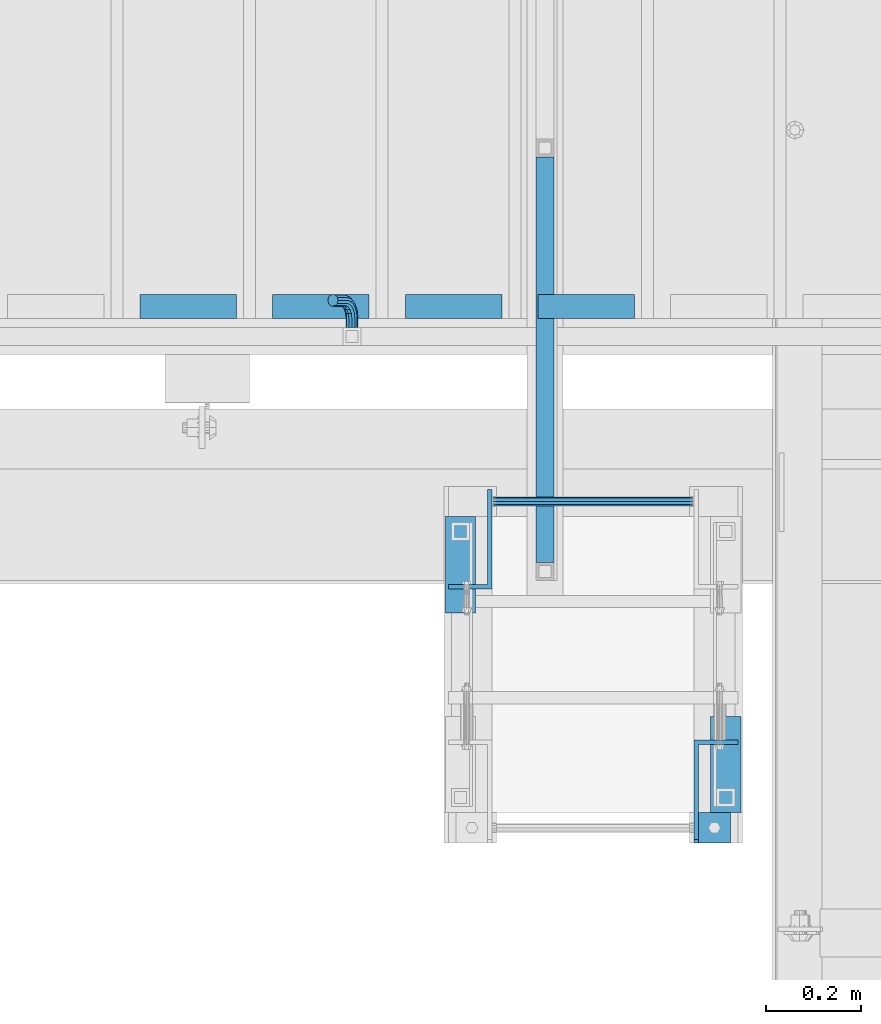
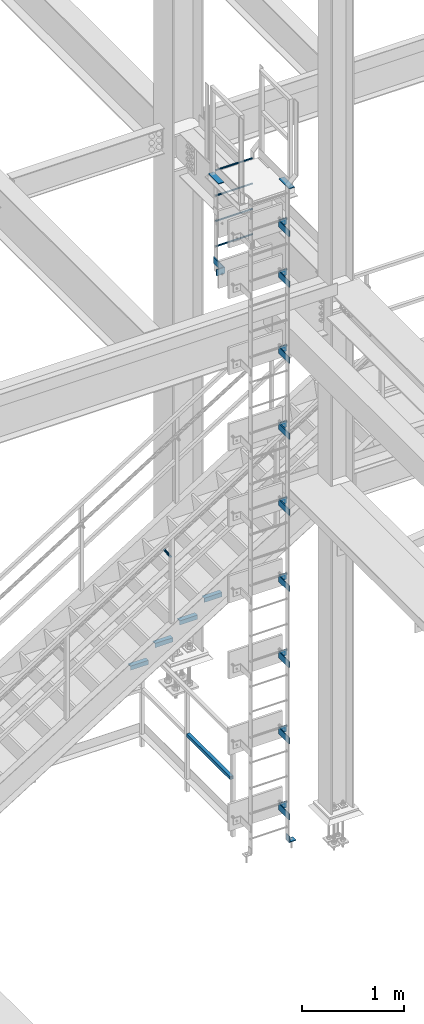
# One storey, part 2414 of 3843: 23 beams, 7 elements without a shape of their own.
"""IFC2X3 building model written with IfcOpenShell, lengths in millimetres."""

from ifc_helpers import new_model, si_unit, frame, origin_with_axes, place, context, subcontext, project, spatial, faceted_brep, material, type_object, element, aggregate, save


model = new_model("IFC2X3")

# Units and contexts
model_context = context("Model", 3, precision=1e-05, world=origin_with_axes())
body_context = subcontext(model_context, "Body", "Model", "MODEL_VIEW")
ifc_project = project(units=[si_unit("LENGTHUNIT", "METRE", prefix="MILLI"), si_unit("AREAUNIT", "SQUARE_METRE"), si_unit("VOLUMEUNIT", "CUBIC_METRE"), si_unit("MASSUNIT", "GRAM", prefix="KILO"), si_unit("TIMEUNIT", "SECOND"), si_unit("PLANEANGLEUNIT", "RADIAN"), si_unit("SOLIDANGLEUNIT", "STERADIAN"), si_unit("THERMODYNAMICTEMPERATUREUNIT", "DEGREE_CELSIUS"), si_unit("LUMINOUSINTENSITYUNIT", "LUMEN")], contexts=[model_context])

# Site, building, storey
site_placement = place(None, origin_with_axes())
site = spatial("IfcSite", under=ifc_project, at=site_placement, CompositionType="ELEMENT")
building_placement = place(site_placement, origin_with_axes())
building = spatial("IfcBuilding", under=site, at=building_placement, Name="Undefined", CompositionType="ELEMENT")
storey_placement = place(building_placement, origin_with_axes())
storey = spatial("IfcBuildingStorey", under=building, at=storey_placement, Name="Undefined", CompositionType="ELEMENT", Elevation=0.0)

# Assembly, beams
assembly_1_placement = place(storey_placement, origin_with_axes())
assembly_1 = element("IfcElementAssembly", 1, at=assembly_1_placement, inside=storey, Name="LADDER", AssemblyPlace="NOTDEFINED", PredefinedType="RIGID_FRAME")
ifc_material_1 = material(Name="STEEL/A36")
beam_type_1 = type_object("IfcBeamType", PredefinedType="NOTDEFINED")
beam_1_placement = place(assembly_1_placement, frame((35574.2874231775, 88297.1468750001, 37797.58125), z_axis=(0.0, 0.0, 1.0), x_axis=(0.0, 1.0, 0.0)))
beam_1 = element("IfcBeam", 2, at=beam_1_placement, type_object=beam_type_1, material=ifc_material_1, Name="BENT_PLATE", context=body_context, shape_type="Brep", body=[
    faceted_brep([(0.0, -4.76250000000073, -38.0999999999985), (0.0, -4.76250000000073, 38.0999999999985), (0.0, 4.76250000000073, 38.0999999999985), (0.0, 4.76250000000073, -38.0999999999985), (209.946875000009, 4.76249999998981, 38.0999999999985), (209.946875000009, 4.76249999998981, -38.0999999999985), (200.421875000015, -4.76250000000437, -38.0999999999985), (200.421875000015, -4.76250000000437, 38.0999999999985), (209.946875000009, -87.3125, 38.0999999999985), (209.946875000009, -87.3125, -38.0999999999985), (200.421875000015, -87.3125, 38.0999999999985), (200.421875000015, -87.3125, -38.0999999999985)], [[[0, 1, 2, 3]], [[3, 2, 4, 5]], [[1, 0, 6, 7]], [[5, 4, 8, 9]], [[4, 2, 1, 7, 10, 8]], [[7, 6, 11, 10]], [[6, 0, 3, 5, 9, 11]], [[10, 11, 9, 8]]]),
])
beam_2_placement = place(assembly_1_placement, frame((35574.2874231775, 88297.1468750001, 37187.98125), z_axis=(0.0, 0.0, 1.0), x_axis=(0.0, 1.0, 0.0)))
beam_2 = element("IfcBeam", 3, at=beam_2_placement, type_object=beam_type_1, material=ifc_material_1, Name="BENT_PLATE", context=body_context, shape_type="Brep", body=[
    faceted_brep([(0.0, -4.76250000000073, -38.0999999999985), (0.0, -4.76250000000073, 38.0999999999985), (0.0, 4.76250000000073, 38.0999999999985), (0.0, 4.76250000000073, -38.0999999999985), (209.946875000009, 4.76249999998981, 38.0999999999985), (209.946875000009, 4.76249999998981, -38.0999999999985), (200.421875000015, -4.76250000000437, -38.0999999999985), (200.421875000015, -4.76250000000437, 38.0999999999985), (209.946875000009, -87.3125, 38.0999999999985), (209.946875000009, -87.3125, -38.0999999999985), (200.421875000015, -87.3125, 38.0999999999985), (200.421875000015, -87.3125, -38.0999999999985)], [[[0, 1, 2, 3]], [[3, 2, 4, 5]], [[1, 0, 6, 7]], [[5, 4, 8, 9]], [[4, 2, 1, 7, 10, 8]], [[7, 6, 11, 10]], [[6, 0, 3, 5, 9, 11]], [[10, 11, 9, 8]]]),
])
beam_3_placement = place(assembly_1_placement, frame((35574.2874231775, 88297.1468750001, 36273.58125), z_axis=(0.0, 0.0, 1.0), x_axis=(0.0, 1.0, 0.0)))
beam_3 = element("IfcBeam", 4, at=beam_3_placement, type_object=beam_type_1, material=ifc_material_1, Name="BENT_PLATE", context=body_context, shape_type="Brep", body=[
    faceted_brep([(0.0, -4.76250000000073, -38.0999999999985), (0.0, -4.76250000000073, 38.0999999999985), (0.0, 4.76250000000073, 38.0999999999985), (0.0, 4.76250000000073, -38.0999999999985), (209.946875000009, 4.76249999998981, 38.0999999999985), (209.946875000009, 4.76249999998981, -38.0999999999985), (200.421875000015, -4.76250000000437, -38.0999999999985), (200.421875000015, -4.76250000000437, 38.0999999999985), (209.946875000009, -87.3125, 38.0999999999985), (209.946875000009, -87.3125, -38.0999999999985), (200.421875000015, -87.3125, 38.0999999999985), (200.421875000015, -87.3125, -38.0999999999985)], [[[0, 1, 2, 3]], [[3, 2, 4, 5]], [[1, 0, 6, 7]], [[5, 4, 8, 9]], [[4, 2, 1, 7, 10, 8]], [[7, 6, 11, 10]], [[6, 0, 3, 5, 9, 11]], [[10, 11, 9, 8]]]),
])
beam_4_placement = place(assembly_1_placement, frame((35574.2874231775, 88297.1468750001, 35359.18125), z_axis=(0.0, 0.0, 1.0), x_axis=(0.0, 1.0, 0.0)))
beam_4 = element("IfcBeam", 5, at=beam_4_placement, type_object=beam_type_1, material=ifc_material_1, Name="BENT_PLATE", context=body_context, shape_type="Brep", body=[
    faceted_brep([(0.0, -4.76250000000073, -38.0999999999985), (0.0, -4.76250000000073, 38.0999999999985), (0.0, 4.76250000000073, 38.0999999999985), (0.0, 4.76250000000073, -38.0999999999985), (209.946875000009, 4.76249999998981, 38.0999999999985), (209.946875000009, 4.76249999998981, -38.0999999999985), (200.421875000015, -4.76250000000437, -38.0999999999985), (200.421875000015, -4.76250000000437, 38.0999999999985), (209.946875000009, -87.3125, 38.0999999999985), (209.946875000009, -87.3125, -38.0999999999985), (200.421875000015, -87.3125, 38.0999999999985), (200.421875000015, -87.3125, -38.0999999999985)], [[[0, 1, 2, 3]], [[3, 2, 4, 5]], [[1, 0, 6, 7]], [[5, 4, 8, 9]], [[4, 2, 1, 7, 10, 8]], [[7, 6, 11, 10]], [[6, 0, 3, 5, 9, 11]], [[10, 11, 9, 8]]]),
])
beam_5_placement = place(assembly_1_placement, frame((35574.2874231775, 88297.1468750001, 34444.78125), z_axis=(0.0, 0.0, 1.0), x_axis=(0.0, 1.0, 0.0)))
beam_5 = element("IfcBeam", 6, at=beam_5_placement, type_object=beam_type_1, material=ifc_material_1, Name="BENT_PLATE", context=body_context, shape_type="Brep", body=[
    faceted_brep([(0.0, -4.76250000000073, -38.0999999999985), (0.0, -4.76250000000073, 38.0999999999985), (0.0, 4.76250000000073, 38.0999999999985), (0.0, 4.76250000000073, -38.0999999999985), (209.946875000009, 4.76249999998981, 38.0999999999985), (209.946875000009, 4.76249999998981, -38.0999999999985), (200.421875000015, -4.76250000000437, -38.0999999999985), (200.421875000015, -4.76250000000437, 38.0999999999985), (209.946875000009, -87.3125, 38.0999999999985), (209.946875000009, -87.3125, -38.0999999999985), (200.421875000015, -87.3125, 38.0999999999985), (200.421875000015, -87.3125, -38.0999999999985)], [[[0, 1, 2, 3]], [[3, 2, 4, 5]], [[1, 0, 6, 7]], [[5, 4, 8, 9]], [[4, 2, 1, 7, 10, 8]], [[7, 6, 11, 10]], [[6, 0, 3, 5, 9, 11]], [[10, 11, 9, 8]]]),
])
beam_6_placement = place(assembly_1_placement, frame((35574.2874231775, 88297.1468750001, 33530.38125), z_axis=(0.0, 0.0, 1.0), x_axis=(0.0, 1.0, 0.0)))
beam_6 = element("IfcBeam", 7, at=beam_6_placement, type_object=beam_type_1, material=ifc_material_1, Name="BENT_PLATE", context=body_context, shape_type="Brep", body=[
    faceted_brep([(0.0, -4.76250000000073, -38.0999999999985), (0.0, -4.76250000000073, 38.0999999999985), (0.0, 4.76250000000073, 38.0999999999985), (0.0, 4.76250000000073, -38.0999999999985), (209.946875000009, 4.76249999998981, 38.0999999999985), (209.946875000009, 4.76249999998981, -38.0999999999985), (200.421875000015, -4.76250000000437, -38.0999999999985), (200.421875000015, -4.76250000000437, 38.0999999999985), (209.946875000009, -87.3125, 38.0999999999985), (209.946875000009, -87.3125, -38.0999999999985), (200.421875000015, -87.3125, 38.0999999999985), (200.421875000015, -87.3125, -38.0999999999985)], [[[0, 1, 2, 3]], [[3, 2, 4, 5]], [[1, 0, 6, 7]], [[5, 4, 8, 9]], [[4, 2, 1, 7, 10, 8]], [[7, 6, 11, 10]], [[6, 0, 3, 5, 9, 11]], [[10, 11, 9, 8]]]),
])
beam_7_placement = place(assembly_1_placement, frame((35574.2874231775, 88297.1468750001, 32615.98125), z_axis=(0.0, 0.0, 1.0), x_axis=(0.0, 1.0, 0.0)))
beam_7 = element("IfcBeam", 8, at=beam_7_placement, type_object=beam_type_1, material=ifc_material_1, Name="BENT_PLATE", context=body_context, shape_type="Brep", body=[
    faceted_brep([(0.0, -4.76250000000073, -38.0999999999985), (0.0, -4.76250000000073, 38.0999999999985), (0.0, 4.76250000000073, 38.0999999999985), (0.0, 4.76250000000073, -38.0999999999985), (209.946875000009, 4.76249999998981, 38.0999999999985), (209.946875000009, 4.76249999998981, -38.0999999999985), (200.421875000015, -4.76250000000437, -38.0999999999985), (200.421875000015, -4.76250000000437, 38.0999999999985), (209.946875000009, -87.3125, 38.0999999999985), (209.946875000009, -87.3125, -38.0999999999985), (200.421875000015, -87.3125, 38.0999999999985), (200.421875000015, -87.3125, -38.0999999999985)], [[[0, 1, 2, 3]], [[3, 2, 4, 5]], [[1, 0, 6, 7]], [[5, 4, 8, 9]], [[4, 2, 1, 7, 10, 8]], [[7, 6, 11, 10]], [[6, 0, 3, 5, 9, 11]], [[10, 11, 9, 8]]]),
])

# Assembly, beam
assembly_2_placement = place(storey_placement, origin_with_axes())
assembly_2 = element("IfcElementAssembly", 9, at=assembly_2_placement, inside=storey, Name="LADDER", AssemblyPlace="NOTDEFINED", PredefinedType="RIGID_FRAME")
beam_8_placement = place(assembly_2_placement, frame((35139.3126300871, 89034.2771634689, 37188.0390686035), z_axis=(0.0, 0.0, 1.0), x_axis=(0.0, -1.0, 0.0)))
beam_8 = element("IfcBeam", 10, at=beam_8_placement, type_object=beam_type_1, material=ifc_material_1, Name="BENT_PLATE", context=body_context, shape_type="Brep", body=[
    faceted_brep([(0.0, -4.76250000000073, -38.0999999999985), (0.0, -4.76250000000073, 38.0999999999985), (0.0, 4.76250000000073, 38.0999999999985), (0.0, 4.76250000000073, -38.0999999999985), (209.745611795166, 4.76250006725604, 38.0999999999985), (209.745611795166, 4.76250006725604, -38.0999999999985), (200.220604794216, -4.76249993579404, -38.0999999999985), (200.220604794216, -4.76249993579404, 38.0999999999985), (209.745544119389, -87.3125069349044, 38.0999999999985), (209.745544119389, -87.3125069349044, -38.0999999999985), (200.22054411938, -87.3124999339561, 38.0999999999985), (200.22054411938, -87.3124999339561, -38.0999999999985)], [[[0, 1, 2, 3]], [[3, 2, 4, 5]], [[1, 0, 6, 7]], [[5, 4, 8, 9]], [[4, 2, 1, 7, 10, 8]], [[7, 6, 11, 10]], [[6, 0, 3, 5, 9, 11]], [[10, 11, 9, 8]]]),
])

# Beam
beam_9_placement = place(assembly_1_placement, frame((35574.2874231775, 88297.1710895375, 31701.6384658952), z_axis=(0.0, 0.000284300999875996, 0.99999995958647), x_axis=(0.0, 0.99999995958647, -0.000284300999878262)))
beam_9 = element("IfcBeam", 11, at=beam_9_placement, type_object=beam_type_1, material=ifc_material_1, Name="BENT_PLATE", context=body_context, shape_type="Brep", body=[
    faceted_brep([(0.0, -4.76250000000073, -38.0999999999985), (0.0, -4.76250000000073, 38.0999999999985), (0.0, 4.76250000000073, 38.0999999999985), (0.0, 4.76250000000073, -38.0999999999985), (209.9131736126, 4.76249999998981, 38.099999999813), (209.913173612542, 4.76249999998981, -38.1000000001295), (200.388173612504, -4.76250000000437, -38.1000000001222), (200.388173612562, -4.76250000000437, 38.0999999998203), (209.9131736126, -87.3125000188884, 38.099999999813), (209.913173612542, -87.3125000188884, -38.1000000001295), (200.388173612562, -87.3125000188884, 38.0999999998203), (200.388173612504, -87.3125000188884, -38.1000000001222)], [[[0, 1, 2, 3]], [[3, 2, 4, 5]], [[1, 0, 6, 7]], [[5, 4, 8, 9]], [[4, 2, 1, 7, 10, 8]], [[7, 6, 11, 10]], [[6, 0, 3, 5, 9, 11]], [[10, 11, 9, 8]]]),
])

beam_10_placement = place(assembly_1_placement, frame((35574.2876798629, 88296.9241128497, 30787.2367905276), z_axis=(0.0, 2.02899999567308e-06, 0.999999999997942), x_axis=(0.0, 0.999999999997942, -2.02899998962774e-06)))
beam_10 = element("IfcBeam", 12, at=beam_10_placement, type_object=beam_type_1, material=ifc_material_1, Name="BENT_PLATE", context=body_context, shape_type="Brep", body=[
    faceted_brep([(0.0, -4.76250000000073, -38.0999999999985), (0.0, -4.76250000000073, 38.0999999999985), (0.0, 4.76250000000073, 38.0999999999985), (0.0, 4.76250000000073, -38.0999999999985), (210.094866646919, 4.76249999998981, 38.1000000001186), (210.094866646992, 4.76249999998981, -38.0999999999876), (200.569866646983, -4.76250000000437, -38.0999999999876), (200.569866646925, -4.76250000000437, 38.100000000115), (210.094866647079, -87.3124999846914, 38.1000000004824), (210.094866646832, -87.3124999850115, -38.0999999996238), (200.569866647085, -87.3124999846914, 38.1000000004788), (200.569866646823, -87.3124999850115, -38.0999999996275)], [[[0, 1, 2, 3]], [[3, 2, 4, 5]], [[1, 0, 6, 7]], [[5, 4, 8, 9]], [[4, 2, 1, 7, 10, 8]], [[7, 6, 11, 10]], [[6, 0, 3, 5, 9, 11]], [[10, 11, 9, 8]]]),
])

ifc_material_2 = material(Name="STEEL/A572-50")
beam_type_2 = type_object("IfcBeamType", Name="L3X3X3/8", PredefinedType="NOTDEFINED")
beam_11_placement = place(assembly_1_placement, frame((35607.6251798629, 88353.6303589472, 30518.1), z_axis=(1.0, 0.0, 0.0), x_axis=(0.0, -1.0, 0.0)))
beam_11 = element("IfcBeam", 13, at=beam_11_placement, type_object=beam_type_2, material=ifc_material_2, Name="ANGLE", ObjectType="L3X3X3/8", context=body_context, shape_type="Brep", body=[
    faceted_brep([(0.0, 38.0999999999985, -38.0999999999985), (0.0, 38.0999999999985, 38.0999999999985), (63.5, 38.0999999999985, 38.0999999999985), (63.5, 38.0999999999985, -38.0999999999985), (0.0, 28.5750000000007, 38.0999999999985), (63.5, 28.5750000000007, 38.0999999999985), (0.0, 28.5750000000007, -28.5750000000007), (63.5, 28.5750000000007, -28.5750000000007), (0.0, -38.0999999999985, -28.5750000000007), (63.5, -38.0999999999985, -28.5750000000007), (0.0, -38.0999999999985, -38.0999999999985), (63.5, -38.0999999999985, -38.0999999999985)], [[[0, 1, 2, 3]], [[1, 4, 5, 2]], [[4, 6, 7, 5]], [[6, 8, 9, 7]], [[8, 10, 11, 9]], [[10, 0, 3, 11]], [[5, 7, 9, 11, 3, 2]], [[10, 8, 6, 4, 1, 0]]]),
])

aggregate(assembly_1, [beam_1, beam_2, beam_3, beam_4, beam_5, beam_6, beam_7, beam_11, beam_9, beam_10])

# Assembly, beam
assembly_3_placement = place(storey_placement, origin_with_axes())
assembly_3 = element("IfcElementAssembly", 14, at=assembly_3_placement, inside=storey, Name="RAIL", AssemblyPlace="NOTDEFINED", PredefinedType="RIGID_FRAME")
ifc_material_3 = material()
beam_type_3 = type_object("IfcBeamType", Name="HSS1-1/2X1-1/2X1/4", PredefinedType="NOTDEFINED")
beam_12_placement = place(assembly_3_placement, frame((35255.2000000271, 88861.9, 31013.4), z_axis=(0.0, 0.0, 1.0), x_axis=(0.0, 1.0, 0.0)))
beam_12 = element("IfcBeam", 15, at=beam_12_placement, type_object=beam_type_3, material=ifc_material_3, Name="RAIL", ObjectType="HSS1-1/2X1-1/2X1/4", context=body_context, shape_type="Brep", body=[
    faceted_brep([(873.125000004831, -19.0499999999884, 19.0499992350015), (873.125000004831, -19.0499992350015, -19.0499992350015), (873.125000004831, 19.0499992350015, -19.0499992350015), (873.125000004831, 19.0499992350015, 19.0499992350015), (873.125000004831, -12.6999993299978, 12.6999993300014), (873.125000004831, 12.6999993299978, 12.6999993300014), (873.125000004831, 12.6999993299978, -12.6999993300014), (873.125000004831, -12.6999993299978, -12.6999993300014), (19.0499992350015, 19.0499992350015, -19.0499992350015), (19.0499992350015, 19.0499992350015, 19.0499992350015), (19.0499992350015, -19.0499992350015, 19.0499992350015), (19.0499992350015, -19.0499992350015, -19.0499992350015), (19.0499992350015, 12.6999993299978, 12.6999993299978), (19.0499992350015, -12.6999993299978, 12.6999993299978), (19.0499992350015, -12.6999993299978, -12.6999993299978), (19.0499992350015, 12.6999993299978, -12.6999993299978)], [[[0, 1, 2, 3], [4, 5, 6, 7]], [[8, 9, 3, 2]], [[9, 10, 0, 3]], [[10, 11, 1, 0]], [[11, 8, 2, 1]], [[11, 10, 9, 8], [12, 13, 14, 15]], [[14, 13, 4, 7]], [[15, 14, 7, 6]], [[12, 15, 6, 5]], [[13, 12, 5, 4]]]),
])
aggregate(assembly_3, [beam_12])

# Assembly, beams
assembly_4_placement = place(storey_placement, origin_with_axes())
assembly_4 = element("IfcElementAssembly", 16, at=assembly_4_placement, inside=storey, Name="STAIR", AssemblyPlace="NOTDEFINED", PredefinedType="RIGID_FRAME")
beam_type_4 = type_object("IfcBeamType", Name="L2X2X3/16", PredefinedType="NOTDEFINED")
beam_13_placement = place(assembly_4_placement, frame((35443.6169176732, 89420.7000000434, 32839.0250000043), z_axis=(0.0, 1.0, 0.0), x_axis=(-1.0, 0.0, 0.0)))
beam_13 = element("IfcBeam", 17, at=beam_13_placement, type_object=beam_type_4, material=ifc_material_1, Name="ANGLE", ObjectType="L2X2X3/16", context=body_context, shape_type="Brep", body=[
    faceted_brep([(0.0, 25.4000000000015, -25.4000000000015), (0.0, 25.4000000000015, 25.4000000000015), (203.199999999997, 25.4000000000015, 25.4000000000015), (203.199999999997, 25.4000000000015, -25.4000000000015), (0.0, 20.6375000000007, 25.4000000000015), (203.199999999997, 20.6375000000007, 25.4000000000015), (0.0, 20.6375000000007, -20.6375000000007), (203.199999999997, 20.6375000000007, -20.6375000000007), (0.0, -25.4000000000015, -20.6375000000007), (203.199999999997, -25.4000000000015, -20.6375000000007), (0.0, -25.4000000000015, -25.4000000000015), (203.199999999997, -25.4000000000015, -25.4000000000015)], [[[0, 1, 2, 3]], [[1, 4, 5, 2]], [[4, 6, 7, 5]], [[6, 8, 9, 7]], [[8, 10, 11, 9]], [[10, 0, 3, 11]], [[5, 7, 9, 11, 3, 2]], [[10, 8, 6, 4, 1, 0]]]),
])
beam_14_placement = place(assembly_4_placement, frame((35164.2169176732, 89420.7000000434, 32664.8535714329), z_axis=(0.0, 1.0, 0.0), x_axis=(-1.0, 0.0, 0.0)))
beam_14 = element("IfcBeam", 18, at=beam_14_placement, type_object=beam_type_4, material=ifc_material_1, Name="ANGLE", ObjectType="L2X2X3/16", context=body_context, shape_type="Brep", body=[
    faceted_brep([(0.0, 25.4000000000015, -25.4000000000015), (0.0, 25.4000000000015, 25.4000000000015), (203.199999999997, 25.4000000000015, 25.4000000000015), (203.199999999997, 25.4000000000015, -25.4000000000015), (0.0, 20.6375000000007, 25.4000000000015), (203.199999999997, 20.6375000000007, 25.4000000000015), (0.0, 20.6375000000007, -20.6375000000007), (203.199999999997, 20.6375000000007, -20.6375000000007), (0.0, -25.4000000000015, -20.6375000000007), (203.199999999997, -25.4000000000015, -20.6375000000007), (0.0, -25.4000000000015, -25.4000000000015), (203.199999999997, -25.4000000000015, -25.4000000000015)], [[[0, 1, 2, 3]], [[1, 4, 5, 2]], [[4, 6, 7, 5]], [[6, 8, 9, 7]], [[8, 10, 11, 9]], [[10, 0, 3, 11]], [[5, 7, 9, 11, 3, 2]], [[10, 8, 6, 4, 1, 0]]]),
])
beam_15_placement = place(assembly_4_placement, frame((34884.8169176732, 89420.7000000434, 32490.6821428615), z_axis=(0.0, 1.0, 0.0), x_axis=(-1.0, 0.0, 0.0)))
beam_15 = element("IfcBeam", 19, at=beam_15_placement, type_object=beam_type_4, material=ifc_material_1, Name="ANGLE", ObjectType="L2X2X3/16", context=body_context, shape_type="Brep", body=[
    faceted_brep([(0.0, 25.4000000000015, -25.4000000000015), (0.0, 25.4000000000015, 25.4000000000015), (203.199999999997, 25.4000000000015, 25.4000000000015), (203.199999999997, 25.4000000000015, -25.4000000000015), (0.0, 20.6375000000007, 25.4000000000015), (203.199999999997, 20.6375000000007, 25.4000000000015), (0.0, 20.6375000000007, -20.6375000000007), (203.199999999997, 20.6375000000007, -20.6375000000007), (0.0, -25.4000000000015, -20.6375000000007), (203.199999999997, -25.4000000000015, -20.6375000000007), (0.0, -25.4000000000015, -25.4000000000015), (203.199999999997, -25.4000000000015, -25.4000000000015)], [[[0, 1, 2, 3]], [[1, 4, 5, 2]], [[4, 6, 7, 5]], [[6, 8, 9, 7]], [[8, 10, 11, 9]], [[10, 0, 3, 11]], [[5, 7, 9, 11, 3, 2]], [[10, 8, 6, 4, 1, 0]]]),
])
beam_16_placement = place(assembly_4_placement, frame((34605.4169176732, 89420.7000000434, 32316.51071429), z_axis=(0.0, 1.0, 0.0), x_axis=(-1.0, 0.0, 0.0)))
beam_16 = element("IfcBeam", 20, at=beam_16_placement, type_object=beam_type_4, material=ifc_material_1, Name="ANGLE", ObjectType="L2X2X3/16", context=body_context, shape_type="Brep", body=[
    faceted_brep([(0.0, 25.4000000000015, -25.4000000000015), (0.0, 25.4000000000015, 25.4000000000015), (203.199999999997, 25.4000000000015, 25.4000000000015), (203.199999999997, 25.4000000000015, -25.4000000000015), (0.0, 20.6375000000007, 25.4000000000015), (203.199999999997, 20.6375000000007, 25.4000000000015), (0.0, 20.6375000000007, -20.6375000000007), (203.199999999997, 20.6375000000007, -20.6375000000007), (0.0, -25.4000000000015, -20.6375000000007), (203.199999999997, -25.4000000000015, -20.6375000000007), (0.0, -25.4000000000015, -25.4000000000015), (203.199999999997, -25.4000000000015, -25.4000000000015)], [[[0, 1, 2, 3]], [[1, 4, 5, 2]], [[4, 6, 7, 5]], [[6, 8, 9, 7]], [[8, 10, 11, 9]], [[10, 0, 3, 11]], [[5, 7, 9, 11, 3, 2]], [[10, 8, 6, 4, 1, 0]]]),
])
aggregate(assembly_4, [beam_13, beam_14, beam_15, beam_16])

# Beam
beam_type_5 = type_object("IfcBeamType", PredefinedType="NOTDEFINED")
beam_17_placement = place(assembly_2_placement, frame((35147.2501477523, 89009.6477544666, 37362.9359471553), z_axis=(0.0, 1.0, 0.0), x_axis=(1.0, 0.0, 0.0)))
beam_17 = element("IfcBeam", 21, at=beam_17_placement, type_object=beam_type_5, material=ifc_material_2, Name="RUNG", context=body_context, shape_type="Brep", body=[
    faceted_brep([(0.0, -9.52500000000146, 0.0), (0.0, -6.73519209080405, -6.73519209079677), (419.100000000006, -6.73519209080405, -6.73519209079677), (419.100000000006, -9.52500000000146, 0.0), (2.95075507493764e-12, 2.91322521661641e-12, -9.52499961853027), (419.100000000006, 0.0, -9.52499999999418), (0.0, 6.73519209080405, -6.73519209079677), (419.100000000006, 6.73519209080405, -6.73519209079677), (0.0, 9.52500000000146, 0.0), (419.100000000006, 9.52500000000146, 0.0), (0.0, 6.73519209080405, 6.73519209079677), (419.100000000006, 6.73519209080405, 6.73519209079677), (-9.87109982941227e-13, 2.91322521661641e-12, 9.52499961853027), (419.100000000006, 0.0, 9.52499999999418), (0.0, -6.73519209080405, 6.73519209079677), (419.100000000006, -6.73519209080405, 6.73519209079677)], [[[0, 1, 2, 3]], [[1, 4, 5, 2]], [[4, 6, 7, 5]], [[6, 8, 9, 7]], [[8, 10, 11, 9]], [[10, 12, 13, 11]], [[12, 14, 15, 13]], [[14, 0, 3, 15]], [[5, 7, 9, 11, 13, 15, 3, 2]], [[14, 12, 10, 8, 6, 4, 1, 0]]]),
])

beam_18_placement = place(assembly_2_placement, frame((35147.2501477523, 89009.6477544666, 37667.7359471553), z_axis=(0.0, 1.0, 0.0), x_axis=(1.0, 0.0, 0.0)))
beam_18 = element("IfcBeam", 22, at=beam_18_placement, type_object=beam_type_5, material=ifc_material_2, Name="RUNG", context=body_context, shape_type="Brep", body=[
    faceted_brep([(0.0, -9.52500000000146, 0.0), (0.0, -6.73519209080405, -6.73519209079677), (419.100000000006, -6.73519209080405, -6.73519209079677), (419.100000000006, -9.52500000000146, 0.0), (2.95075507493764e-12, 2.91322521661641e-12, -9.52499961853027), (419.100000000006, 0.0, -9.52499999999418), (0.0, 6.73519209080405, -6.73519209079677), (419.100000000006, 6.73519209080405, -6.73519209079677), (0.0, 9.52500000000146, 0.0), (419.100000000006, 9.52500000000146, 0.0), (0.0, 6.73519209080405, 6.73519209079677), (419.100000000006, 6.73519209080405, 6.73519209079677), (-9.87109982941227e-13, 2.91322521661641e-12, 9.52499961853027), (419.100000000006, 0.0, 9.52499999999418), (0.0, -6.73519209080405, 6.73519209079677), (419.100000000006, -6.73519209080405, 6.73519209079677)], [[[0, 1, 2, 3]], [[1, 4, 5, 2]], [[4, 6, 7, 5]], [[6, 8, 9, 7]], [[8, 10, 11, 9]], [[10, 12, 13, 11]], [[12, 14, 15, 13]], [[14, 0, 3, 15]], [[5, 7, 9, 11, 13, 15, 3, 2]], [[14, 12, 10, 8, 6, 4, 1, 0]]]),
])

beam_19_placement = place(assembly_2_placement, frame((35147.2501477523, 89009.6477544666, 37972.5359471553), z_axis=(0.0, 1.0, 0.0), x_axis=(1.0, 0.0, 0.0)))
beam_19 = element("IfcBeam", 23, at=beam_19_placement, type_object=beam_type_5, material=ifc_material_2, Name="RUNG", context=body_context, shape_type="Brep", body=[
    faceted_brep([(0.0, -9.52500000000146, 0.0), (0.0, -6.73519209080405, -6.73519209079677), (419.100000000006, -6.73519209080405, -6.73519209079677), (419.100000000006, -9.52500000000146, 0.0), (2.95075507493764e-12, 2.91322521661641e-12, -9.52499961853027), (419.100000000006, 0.0, -9.52499999999418), (0.0, 6.73519209080405, -6.73519209079677), (419.100000000006, 6.73519209080405, -6.73519209079677), (0.0, 9.52500000000146, 0.0), (419.100000000006, 9.52500000000146, 0.0), (0.0, 6.73519209080405, 6.73519209079677), (419.100000000006, 6.73519209080405, 6.73519209079677), (-9.87109982941227e-13, 2.91322521661641e-12, 9.52499961853027), (419.100000000006, 0.0, 9.52499999999418), (0.0, -6.73519209080405, 6.73519209079677), (419.100000000006, -6.73519209080405, 6.73519209079677)], [[[0, 1, 2, 3]], [[1, 4, 5, 2]], [[4, 6, 7, 5]], [[6, 8, 9, 7]], [[8, 10, 11, 9]], [[10, 12, 13, 11]], [[12, 14, 15, 13]], [[14, 0, 3, 15]], [[5, 7, 9, 11, 13, 15, 3, 2]], [[14, 12, 10, 8, 6, 4, 1, 0]]]),
])

beam_20_placement = place(assembly_2_placement, frame((35147.2501477523, 89009.6477544666, 38277.3359471553), z_axis=(0.0, 1.0, 0.0), x_axis=(1.0, 0.0, 0.0)))
beam_20 = element("IfcBeam", 24, at=beam_20_placement, type_object=beam_type_5, material=ifc_material_2, Name="RUNG", context=body_context, shape_type="Brep", body=[
    faceted_brep([(0.0, -9.52500000000146, 0.0), (0.0, -6.73519209080405, -6.73519209079677), (419.100000000006, -6.73519209080405, -6.73519209079677), (419.100000000006, -9.52500000000146, 0.0), (2.95075507493764e-12, 2.91322521661641e-12, -9.52499961853027), (419.100000000006, 0.0, -9.52499999999418), (0.0, 6.73519209080405, -6.73519209079677), (419.100000000006, 6.73519209080405, -6.73519209079677), (0.0, 9.52500000000146, 0.0), (419.100000000006, 9.52500000000146, 0.0), (0.0, 6.73519209080405, 6.73519209079677), (419.100000000006, 6.73519209080405, 6.73519209079677), (-9.87109982941227e-13, 2.91322521661641e-12, 9.52499961853027), (419.100000000006, 0.0, 9.52499999999418), (0.0, -6.73519209080405, 6.73519209079677), (419.100000000006, -6.73519209080405, 6.73519209079677)], [[[0, 1, 2, 3]], [[1, 4, 5, 2]], [[4, 6, 7, 5]], [[6, 8, 9, 7]], [[8, 10, 11, 9]], [[10, 12, 13, 11]], [[12, 14, 15, 13]], [[14, 0, 3, 15]], [[5, 7, 9, 11, 13, 15, 3, 2]], [[14, 12, 10, 8, 6, 4, 1, 0]]]),
])

aggregate(assembly_2, [beam_8, beam_17, beam_18, beam_19, beam_20])

# Assembly, beam
assembly_5_placement = place(storey_placement, origin_with_axes())
assembly_5 = element("IfcElementAssembly", 25, at=assembly_5_placement, inside=storey, Name="RAIL", AssemblyPlace="NOTDEFINED", PredefinedType="RIGID_FRAME")
beam_type_6 = type_object("IfcBeamType", PredefinedType="NOTDEFINED")
beam_21_placement = place(assembly_5_placement, frame((35077.4000000001, 88977.9023313522, 38289.7062479483), z_axis=(1.0, 0.0, 0.0), x_axis=(0.0, -1.0, 0.0)))
beam_21 = element("IfcBeam", 26, at=beam_21_placement, type_object=beam_type_6, material=ifc_material_1, context=body_context, shape_type="Brep", body=[
    faceted_brep([(0.0, 3.17500000000291, -31.75), (0.0, 3.17500000000291, 31.75), (203.199998088516, 3.17500000000291, 31.75), (203.199998088516, 3.17500000000291, -31.75), (0.0, -3.17500000000291, 31.75), (203.199998088516, -3.17500000000291, 31.75), (0.0, -3.17500000000291, -31.75), (203.199998088516, -3.17500000000291, -31.75)], [[[0, 1, 2, 3]], [[1, 4, 5, 2]], [[4, 6, 7, 5]], [[6, 0, 3, 7]], [[5, 7, 3, 2]], [[6, 4, 1, 0]]]),
])
aggregate(assembly_5, [beam_21])

assembly_6_placement = place(storey_placement, origin_with_axes())
assembly_6 = element("IfcElementAssembly", 27, at=assembly_6_placement, inside=storey, Name="RAIL", AssemblyPlace="NOTDEFINED", PredefinedType="RIGID_FRAME")
beam_22_placement = place(assembly_6_placement, frame((35636.2, 88556.8303579915, 38289.7062479483), z_axis=(1.0, 0.0, 0.0), x_axis=(0.0, -1.0, 0.0)))
beam_22 = element("IfcBeam", 28, at=beam_22_placement, type_object=beam_type_6, material=ifc_material_1, context=body_context, shape_type="Brep", body=[
    faceted_brep([(0.0, 3.17500000000291, -31.75), (0.0, 3.17500000000291, 31.75), (203.199998088516, 3.17500000000291, 31.75), (203.199998088516, 3.17500000000291, -31.75), (0.0, -3.17500000000291, 31.75), (203.199998088516, -3.17500000000291, 31.75), (0.0, -3.17500000000291, -31.75), (203.199998088516, -3.17500000000291, -31.75)], [[[0, 1, 2, 3]], [[1, 4, 5, 2]], [[4, 6, 7, 5]], [[6, 0, 3, 7]], [[5, 7, 3, 2]], [[6, 4, 1, 0]]]),
])
aggregate(assembly_6, [beam_22])

assembly_7_placement = place(storey_placement, origin_with_axes())
assembly_7 = element("IfcElementAssembly", 29, at=assembly_7_placement, inside=storey, Name="RAIL", AssemblyPlace="NOTDEFINED", PredefinedType="RIGID_FRAME")
beam_type_7 = type_object("IfcBeamType", PredefinedType="NOTDEFINED")
beam_23_placement = place(assembly_7_placement, frame((34848.7449537329, 89376.2500000455, 33514.6852611878), z_axis=(0.848616882600527, 0.0, 0.529007926750974), x_axis=(0.0, 1.0, 0.0)))
beam_23 = element("IfcBeam", 30, at=beam_23_placement, type_object=beam_type_7, material=ifc_material_1, Name="BRACKET ARM", context=body_context, shape_type="Brep", body=[
    faceted_brep([(0.0, -12.6999999999971, 0.0), (0.0, -10.9985226280696, -6.34999999999854), (19.0500015258731, -10.9985226280623, -6.34999999999854), (19.0500015258731, -12.6999999999971, -6.33008312433958e-10), (0.0, -6.35000000000582, -10.9985226280623), (19.0500015258731, -6.34999999999854, -10.9985226280623), (0.0, 0.0, -12.6999999999971), (19.0500015258731, 0.0, -12.6999999999971), (0.0, 6.35000000000582, -10.9985226280623), (19.0500015258731, 6.34999999999854, -10.9985226280623), (0.0, 10.9985226280696, -6.34999999999854), (19.0500015258731, 10.9985226280623, -6.34999999999854), (0.0, 12.6999999999971, 0.0), (19.0500015258731, 12.6999999999971, 0.0), (0.0, 10.9985226280696, 6.34999999999854), (19.0500015258731, 10.9985226280623, 6.34999999999854), (0.0, 6.35000000000582, 10.9985226280623), (19.0500015258731, 6.34999999999854, 10.9985226280623), (0.0, 0.0, 12.6999999999971), (19.0500015258731, 0.0, 12.6999999999971), (0.0, -6.35000000000582, 10.9985226280623), (19.0500015258731, -6.34999999999854, 10.9985226280623), (0.0, -10.9985226280696, 6.34999999999854), (19.0500015258731, -10.9985226280623, 6.34999999999854), (38.4903193060891, -8.8330803677236, -3.34694050252438e-10), (37.8391921052389, -7.26112024908798, 6.34999999974389), (36.0602795104642, -2.96644533684594, 10.9985226280041), (33.6302397149266, 2.90018969451194, 12.7000000002226), (31.2001999194181, 8.76682472604443, 10.9985226285644), (29.4212873247307, 13.061499638774, 6.35000000070431), (28.7701601240115, 14.6334597580644, 7.78527464717627e-10), (29.4212873248762, 13.0614996394288, -6.34999999929278), (31.2001999196509, 8.76682472718676, -10.9985226275603), (33.6302397151885, 2.90018969582889, -12.6999999997788), (36.0602795106824, -2.96644533571089, -10.9985226281206), (37.8391921053699, -7.26112024843314, -6.35000000026048), (53.7678987435793, 3.38210125690239, -6.3499999994383), (54.9710249311902, 2.17897506880399, 5.0931703299284e-10), (50.4808968708676, 6.66910312997061, -10.9985226273784), (45.9907688103704, 11.1592311906061, -12.6999999991458), (41.5006407498004, 15.6493592510378, -10.9985226270364), (38.213638876914, 18.9363611235749, -6.34999999884167), (37.0105126890558, 20.1394873109457, 1.20053300634027e-09), (38.2136388766667, 18.9363611228473, 6.35000000115542), (41.5006407493784, 15.6493592497718, 10.9985226290883), (45.9907688098756, 11.1592311891436, 12.7000000008557), (50.4808968704456, 6.66910312870459, 10.9985226287463), (53.7678987433319, 3.38210125617479, 6.35000000055879), (64.4111202489148, 19.3108078951118, -6.34999999821594), (65.9830803677178, 18.6596806939051, 1.77533365786076e-09), (60.1164453365491, 21.0897204901557, -10.9985226262725), (54.2498103051475, 23.5197602857806, -12.6999999981927), (48.3831752736587, 25.9498000811873, -10.9985226262434), (44.0885003610601, 27.7287126756128, -6.34999999817228), (42.516540241937, 28.3798398759754, 1.83354131877422e-09), (44.08850036074, 27.7287126747688, 6.35000000183209), (48.3831752731057, 25.9498000797321, 10.9985226298813), (54.2498103045073, 23.5197602840999, 12.7000000018088), (60.1164453359961, 21.0897204886933, 10.9985226298522), (64.4111202485947, 19.3108078942678, 6.35000000178115), (68.1485226282239, 38.0999984746086, -6.3499999967753), (69.8499999999913, 38.0999984741211, 2.92493496090174e-09), (63.500000000291, 38.0999984749651, -10.9985226249628), (57.1500000003434, 38.0999984750961, -12.6999999970722), (50.8000000002939, 38.0999984749651, -10.998522625312), (46.1514773720992, 38.0999984746086, -6.34999999737192), (44.4499999999971, 38.0999984741211, 2.58296495303512e-09), (46.1514773717645, 38.0999984736336, 6.35000000262517), (50.7999999996973, 38.0999984732771, 10.9985226308127), (57.1499999996449, 38.0999984731461, 12.700000002922), (63.4999999996944, 38.0999984732771, 10.9985226311619), (68.1485226278892, 38.0999984736336, 6.35000000322179), (68.1485226280638, 76.2000000002372, -6.34999999414867), (69.8499999999913, 76.199999999757, 5.84986992180347e-09), (63.5, 76.200000000601, -10.9985226222125), (57.1499999999942, 76.2000000007247, -12.6999999941472), (50.7999999999884, 76.200000000601, -10.9985226222125), (46.1514773719246, 76.2000000002372, -6.34999999414867), (44.4499999999971, 76.199999999757, 5.84986992180347e-09), (46.1514773719246, 76.1999999992695, 6.35000000584841), (50.7999999999884, 76.1999999989057, 10.9985226339122), (57.1499999999942, 76.199999998782, 12.700000005847), (63.5, 76.1999999989057, 10.9985226339122), (68.1485226280638, 76.1999999992695, 6.35000000584841)], [[[0, 1, 2, 3]], [[1, 4, 5, 2]], [[4, 6, 7, 5]], [[6, 8, 9, 7]], [[8, 10, 11, 9]], [[10, 12, 13, 11]], [[12, 14, 15, 13]], [[14, 16, 17, 15]], [[16, 18, 19, 17]], [[18, 20, 21, 19]], [[20, 22, 23, 21]], [[22, 0, 3, 23]], [[22, 20, 18, 16, 14, 12, 10, 8, 6, 4, 1, 0]], [[23, 3, 24, 25]], [[21, 23, 25, 26]], [[19, 21, 26, 27]], [[17, 19, 27, 28]], [[15, 17, 28, 29]], [[13, 15, 29, 30]], [[11, 13, 30, 31]], [[9, 11, 31, 32]], [[7, 9, 32, 33]], [[5, 7, 33, 34]], [[2, 5, 34, 35]], [[3, 2, 35, 24]], [[35, 36, 37, 24]], [[34, 38, 36, 35]], [[33, 39, 38, 34]], [[32, 40, 39, 33]], [[31, 41, 40, 32]], [[30, 42, 41, 31]], [[29, 43, 42, 30]], [[28, 44, 43, 29]], [[27, 45, 44, 28]], [[26, 46, 45, 27]], [[25, 47, 46, 26]], [[24, 37, 47, 25]], [[36, 48, 49, 37]], [[38, 50, 48, 36]], [[39, 51, 50, 38]], [[40, 52, 51, 39]], [[41, 53, 52, 40]], [[42, 54, 53, 41]], [[43, 55, 54, 42]], [[44, 56, 55, 43]], [[45, 57, 56, 44]], [[46, 58, 57, 45]], [[47, 59, 58, 46]], [[37, 49, 59, 47]], [[48, 60, 61, 49]], [[50, 62, 60, 48]], [[51, 63, 62, 50]], [[52, 64, 63, 51]], [[53, 65, 64, 52]], [[54, 66, 65, 53]], [[55, 67, 66, 54]], [[56, 68, 67, 55]], [[57, 69, 68, 56]], [[58, 70, 69, 57]], [[59, 71, 70, 58]], [[49, 61, 71, 59]], [[61, 60, 72, 73]], [[60, 62, 74, 72]], [[62, 63, 75, 74]], [[63, 64, 76, 75]], [[64, 65, 77, 76]], [[65, 66, 78, 77]], [[66, 67, 79, 78]], [[67, 68, 80, 79]], [[68, 69, 81, 80]], [[69, 70, 82, 81]], [[70, 71, 83, 82]], [[71, 61, 73, 83]], [[74, 75, 76, 77, 78, 79, 80, 81, 82, 83, 73, 72]]]),
])
aggregate(assembly_7, [beam_23])

save(model, "model.ifc")
